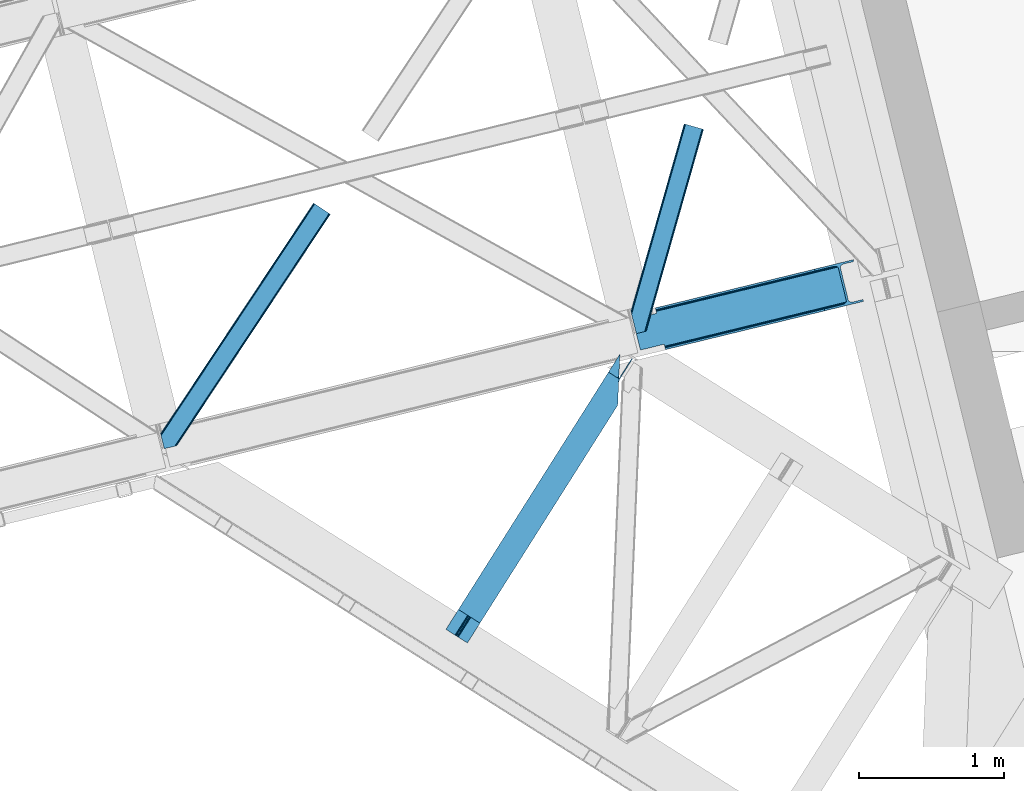
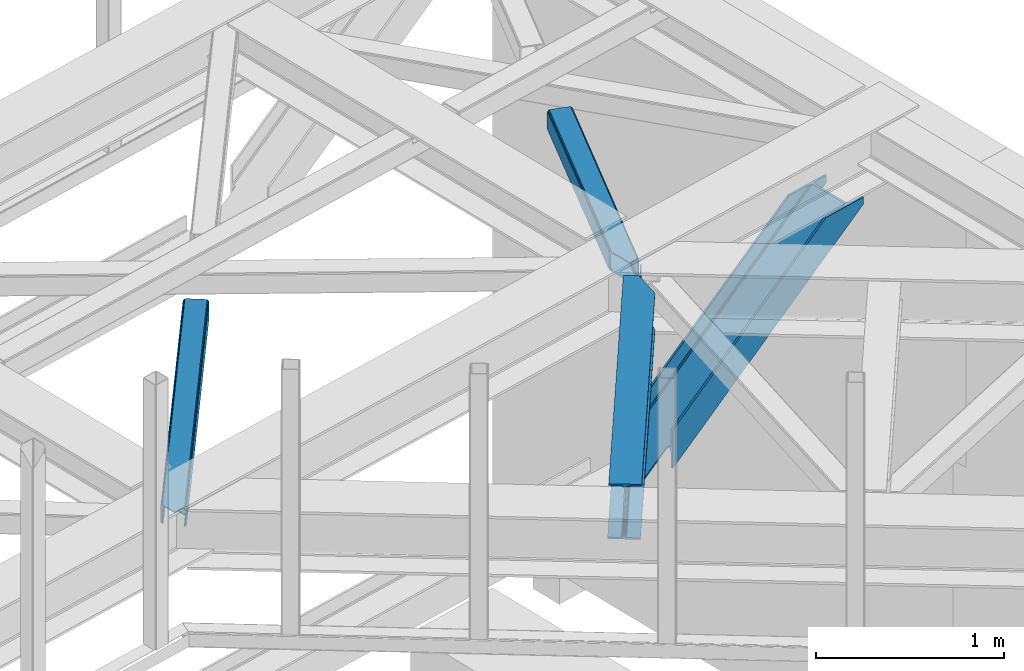
# One storey, part 58 of 67: 3 members, 1 beam.
"""IFC4 building model written with IfcOpenShell, lengths in millimetres."""

from ifc_helpers import new_model, entity, si_unit, converted_unit, derived_unit, direction, frame, origin, place, context, subcontext, project, spatial, triangles, polygons, type_object, element, save


model = new_model("IFC4")

# Units and contexts
model_context = context("Model", 3, precision=0.01, world=origin(), true_north=direction((6.12303176911189e-17, 1.0)))
plan_context = context("Plan", 3, precision=0.01, world=origin(), true_north=direction((6.12303176911189e-17, 1.0)))
body_context = subcontext(model_context, "Body", "Model", "MODEL_VIEW")
ifc_project = project(units=[si_unit("LENGTHUNIT", "METRE", prefix="MILLI"), si_unit("AREAUNIT", "SQUARE_METRE"), si_unit("VOLUMEUNIT", "CUBIC_METRE"), converted_unit("PLANEANGLEUNIT", "DEGREE", entity("IfcRatioMeasure", 0.0174532925199433), si_unit("PLANEANGLEUNIT", "RADIAN"), dimensions=[0, 0, 0, 0, 0, 0, 0]), si_unit("MASSUNIT", "GRAM", prefix="KILO"), derived_unit("MASSDENSITYUNIT", [(si_unit("MASSUNIT", "GRAM", prefix="KILO"), 1), (si_unit("LENGTHUNIT", "METRE"), -3)]), derived_unit("MOMENTOFINERTIAUNIT", [(si_unit("LENGTHUNIT", "METRE"), 4)]), si_unit("TIMEUNIT", "SECOND"), si_unit("FREQUENCYUNIT", "HERTZ"), si_unit("THERMODYNAMICTEMPERATUREUNIT", "DEGREE_CELSIUS"), derived_unit("THERMALTRANSMITTANCEUNIT", [(si_unit("MASSUNIT", "GRAM", prefix="KILO"), 1), (si_unit("THERMODYNAMICTEMPERATUREUNIT", "KELVIN"), -1), (si_unit("TIMEUNIT", "SECOND"), -3)]), derived_unit("VOLUMETRICFLOWRATEUNIT", [(si_unit("LENGTHUNIT", "METRE"), 3), (si_unit("TIMEUNIT", "SECOND"), -1)]), derived_unit("MASSFLOWRATEUNIT", [(si_unit("MASSUNIT", "GRAM", prefix="KILO"), 1), (si_unit("TIMEUNIT", "SECOND"), -1)]), derived_unit("ROTATIONALFREQUENCYUNIT", [(si_unit("TIMEUNIT", "SECOND"), -1)]), si_unit("ELECTRICCURRENTUNIT", "AMPERE"), si_unit("ELECTRICVOLTAGEUNIT", "VOLT"), si_unit("POWERUNIT", "WATT"), si_unit("FORCEUNIT", "NEWTON", prefix="KILO"), si_unit("ILLUMINANCEUNIT", "LUX"), si_unit("LUMINOUSFLUXUNIT", "LUMEN"), si_unit("LUMINOUSINTENSITYUNIT", "CANDELA"), derived_unit("USERDEFINED", [(si_unit("MASSUNIT", "GRAM", prefix="KILO"), -1), (si_unit("LENGTHUNIT", "METRE"), -2), (si_unit("TIMEUNIT", "SECOND"), 3), (si_unit("LUMINOUSFLUXUNIT", "LUMEN"), 1)]), derived_unit("LINEARVELOCITYUNIT", [(si_unit("LENGTHUNIT", "METRE"), 1), (si_unit("TIMEUNIT", "SECOND"), -1)]), si_unit("PRESSUREUNIT", "PASCAL"), derived_unit("USERDEFINED", [(si_unit("LENGTHUNIT", "METRE"), -2), (si_unit("MASSUNIT", "GRAM", prefix="KILO"), 1), (si_unit("TIMEUNIT", "SECOND"), -2)]), derived_unit("LINEARFORCEUNIT", [(si_unit("MASSUNIT", "GRAM", prefix="KILO"), 1), (si_unit("LENGTHUNIT", "METRE"), 1), (si_unit("TIMEUNIT", "SECOND"), -2), (si_unit("LENGTHUNIT", "METRE"), -1)]), derived_unit("PLANARFORCEUNIT", [(si_unit("MASSUNIT", "GRAM", prefix="KILO"), 1), (si_unit("LENGTHUNIT", "METRE"), 1), (si_unit("TIMEUNIT", "SECOND"), -2), (si_unit("LENGTHUNIT", "METRE"), -2)])], contexts=[model_context, plan_context])

# Site, building, storey
site_placement = place(None, origin())
site = spatial("IfcSite", under=ifc_project, at=site_placement, CompositionType="ELEMENT")
building_placement = place(site_placement, origin())
building = spatial("IfcBuilding", under=site, at=building_placement, CompositionType="ELEMENT")
storey_placement = place(building_placement, frame((0.0, 0.0, 19800.0)))
storey = spatial("IfcBuildingStorey", under=building, at=storey_placement, CompositionType="ELEMENT", Elevation=19800.0)

# Member
member_type_1 = type_object("IfcMemberType", PredefinedType="BRACE")
member_1_placement = place(storey_placement, frame((-2187.21835717023, 16968.3557591435, 2617.59591122081)))
element("IfcMember", 1, at=member_1_placement, inside=storey, type_object=member_type_1, ObjectType="Steel Vertical Brace", PredefinedType="BRACE", context=body_context, shape_type="Tessellation", body=[
    polygons([(1585.2294851225, 334.661161692477, 1042.42673521894), (1582.15074591362, 347.291338448318, 1042.42673521894), (1582.15074591362, 347.291338448318, 1088.40408877919), (1585.2294851225, 334.661161692477, 1088.40408877919), (225.056603724453, 3.10463150600978, 5.98026597646167), (221.977864515578, 15.7348082618462, 5.98026597646167), (221.977864515577, 15.7348082618462, 102.718017134371), (1515.53571242156, 331.05321926145, 1088.40408877919), (225.056603724452, 3.10463150600761, 254.823355771723), (1319.00013205867, 269.76494023208, 1088.40408877919), (217.714994841749, 33.2227453083898, 135.689726532239), (216.294038283798, 39.0520576572405, 135.689726532152), (216.294038283802, 39.0520576572405, 125.113895215846), (217.714994841748, 33.2227453083941, 125.113895215941), (219.346324440217, 26.5304015345462, 123.409110506461), (220.729298895395, 20.8569064339283, 118.554294396374), (221.653372883131, 17.0659982053532, 111.288548629352), (221.977864515572, 15.7348082618462, 254.823355771723), (221.977864515573, 15.7348082618462, 158.085604613814), (221.653372883133, 17.0659982053446, 149.515073118633), (220.729298895395, 20.856906433924, 142.249327351612), (219.346324440223, 26.5304015345462, 137.394511241533), (1451.82949340716, 592.400722901503, 1088.40408877919), (1518.44452689923, 608.638842088371, 1088.40408877919), (1515.36578769035, 621.269018844214, 1088.40408877919), (1249.13643462652, 556.372797383815, 1088.40408877919), (1252.21517383539, 543.742620627976, 1088.40408877919), (1379.16824824607, 574.688775652657, 1088.40408877919), (1390.74021368898, 576.099276446501, 1088.40408877919), (1401.19943555815, 574.632661393906, 1088.40408877918), (1408.95359213711, 570.512209341736, 1088.40408877919), (1412.8221833783, 564.365221762941, 1088.40408877919), (1468.00266304505, 337.993592215981, 1088.40408877919), (1467.39673100087, 330.755892246851, 1088.40408877919), (1462.40852333225, 323.529354097781, 1088.40408877919), (1453.79744943855, 317.414152693241, 1088.40408877919), (1442.87446726047, 313.341272012599, 1088.40408877919), (1315.92139284979, 282.395116987918, 1088.40408877918), (1503.96374697866, 329.64271846761, 1088.40408877919), (1493.50452510946, 331.109333520199, 1088.40408877918), (1485.7503685305, 335.229785572367, 1088.40408877918), (1481.8817772893, 341.376773151153, 1088.40408877919), (1426.70129762255, 567.748402698115, 1088.40408877919), (1427.30722966674, 574.986102667243, 1088.40408877919), (1432.29543733536, 582.212640816317, 1088.40408877919), (1440.90651122909, 588.327842220875, 1088.40408877919), (3.24860138789518e-12, 212.769900732995, 1.8192167772213e-10), (163.220745767809, 252.556684355379, 124.373576309325), (163.955471732924, 253.765062506503, 125.113895215868), (162.534515175014, 259.594374855358, 125.113895215928), (215.085660132705, 39.7867836223989, 124.373576309312), (51.8649143648549, 4.33146851719357e-12, 6.49720277579036e-11), (162.534515175012, 259.594374855358, 135.689726532226), (163.95547173292, 253.765062506501, 135.68972653217), (163.220745767806, 252.556684355379, 134.949407625623), (2.8966695708732e-11, 212.769900732999, 10.5758313165188), (51.8649143648817, 1.08286712929839e-11, 10.5758313164365), (215.085660132696, 39.7867836223968, 134.949407625615), (160.903185576499, 266.286718629312, 137.394511241728), (159.520211121322, 271.960213729928, 142.249327351807), (158.596137133586, 275.751121958501, 149.515073118828), (158.271645501173, 277.082311901899, 158.085604613814), (158.271645501172, 277.082311901899, 254.823355771723), (155.192906292298, 289.712488657742, 254.823355771723), (155.192906292296, 289.712488657742, 5.98026597646167), (158.271645501172, 277.082311901899, 5.98026597646167), (158.271645501173, 277.082311901904, 102.718017134371), (158.59613713359, 275.751121958499, 111.28854862956), (159.520211121322, 271.960213729926, 118.554294396582), (160.903185576492, 266.28671862931, 123.409110506656), (1518.44452689923, 608.638842088371, 1042.42673521895), (1515.36578769035, 621.269018844214, 1042.42673521894)], [[[1, 2, 3, 4]], [[5, 6, 2, 1]], [[6, 7, 8, 3, 2]], [[9, 5, 1, 4, 10]], [[11, 12, 13, 14, 15, 16, 17, 7, 6, 5, 9, 18, 19, 20, 21, 22]], [[23, 24, 25, 26, 27, 28, 29, 30, 31, 32, 33, 34, 35, 36, 37, 38, 10, 4, 3, 8, 39, 40, 41, 42, 43, 44, 45, 46]], [[42, 41, 15, 14]], [[41, 40, 16, 15]], [[40, 39, 17, 16]], [[39, 8, 7, 17]], [[18, 9, 10, 38]], [[19, 18, 38, 37]], [[37, 36, 20, 19]], [[36, 35, 21, 20]], [[35, 34, 22, 21]], [[34, 33, 11, 22]], [[47, 48, 49, 50, 43, 42, 14, 13, 51, 52]], [[53, 54, 55, 56, 57, 58, 12, 11, 33, 32]], [[58, 57, 52, 51]], [[57, 56, 47, 52]], [[56, 55, 48, 47]], [[54, 53, 59, 60, 61, 62, 63, 64, 65, 66, 67, 68, 69, 70, 50, 49]], [[23, 46, 68, 67]], [[46, 45, 69, 68]], [[45, 44, 70, 69]], [[44, 43, 50, 70]], [[67, 66, 71, 24, 23]], [[72, 25, 24, 71]], [[66, 65, 72, 71]], [[65, 64, 26, 25, 72]], [[32, 31, 59, 53]], [[31, 30, 60, 59]], [[30, 29, 61, 60]], [[29, 28, 62, 61]], [[63, 62, 28, 27]], [[64, 63, 27, 26]]], closed=False),
])

# Beam
beam_type = type_object("IfcBeamType", PredefinedType="BEAM")
beam_placement = place(storey_placement, frame((-3471.97848129272, 14954.9604217529, 3863.99976196289)))
element("IfcBeam", 2, at=beam_placement, inside=storey, type_object=beam_type, ObjectType="Steel Beam", PredefinedType="BEAM", context=body_context, shape_type="Tessellation", body=[
    triangles([(1188.72613334656, 1816.41354675293, 230.999853515623), (1188.08329467773, 1793.75679016113, 228.313970947263), (1188.92815589905, 1796.73218994141, 227.025677490234), (1187.41618423462, 1786.02702941895, 230.999853515623), (1190.21528663635, 1815.46941833496, 227.193109130858), (1191.30315628052, 1805.13516540527, 223.384039306638), (1194.96863021851, 1812.46611328125, 221.005114746094), (1191.70894546509, 1814.52645263672, 223.384039306638), (1191.71897392273, 1805.96185913086, 223.116613769529), (163.219397735596, 181.395904541016, 217.00070800781), (1194.53856925964, 1812.73818969727, 217.00070800781), (164.249276733398, 180.744781494141, 223.123590087889), (167.180783843994, 178.891406250001, 228.313970947263), (1187.27709388733, 1782.76792602539, 231.783526611329), (1186.75067253113, 1770.47332763672, 232.99973144531), (171.567144012451, 176.117156982422, 231.783526611329), (176.744734954834, 172.846426391601, 232.99973144531), (1180.87254295349, 1633.92584838867, 232.99973144531), (234.219715118408, 136.50910949707, 232.99973144531), (1188.72613334656, 1816.41354675293, 244.001385498046), (1180.87254295349, 1633.92584838867, 244.001385498046), (234.219715118408, 136.50910949707, 244.001385498046), (1117.61957244873, 1861.36429138184, 244.001385498046), (86.3005462646483, 230.022006225587, 244.001385498046), (1117.61957244873, 1861.36429138184, 232.99973144531), (86.3005462646483, 230.022006225587, 232.99973144531), (1175.09905815125, 1825.02813720703, 232.99973144531), (143.779886627197, 193.685852050781, 232.99973144531), (1187.59422569275, 1817.12978210449, 223.123590087889), (1188.62410469055, 1816.47865905762, 217.00070800781), (157.300572967529, 185.135211181641, 217.00070800781), (156.270693969726, 185.786334228516, 223.123590087889), (1184.66271858215, 1818.98315734863, 228.313970947263), (153.339186859131, 187.639709472656, 228.313970947263), (1180.27214355469, 1821.75624389649, 231.783526611329), (148.953117370605, 190.413958740235, 231.783526611329), (1188.62410469055, 1816.47865905762, 204.001501464842), (1194.53856925964, 1812.73818969727, 204.001501464842), (163.219397735596, 181.395904541016, 204.001501464842), (157.300572967529, 185.135211181641, 204.001501464842), (1284.44601745605, 1954.95276489258, 202.999237060547), (1278.52704734802, 1958.6920715332, 202.999237060547), (1195.07443771362, 1813.58348693848, 202.999237060547), (1189.15546760559, 1817.32395629883, 202.999237060547), (1284.44601745605, 1954.95276489258, 119.99965209961), (1278.52704734802, 1958.6920715332, 119.99965209961), (162.88715057373, 180.872680664063, 203.057373046875), (156.76921005249, 184.291076660156, 202.999237060547), (76.9188514709472, 44.8867950439453, 202.999237060547), (71.0000267028809, 48.626101684571, 202.999237060547), (1200.5501209259, 1835.34494934082, 119.99965209961), (1199.94579734802, 1821.28883056641, 119.99965209961), (1196.02728652954, 1828.19306030274, 119.162493896485), (1195.42281761169, 1814.13694152832, 119.162493896485), (1192.19612503052, 1822.13180236816, 116.778918457032), (1191.59180145264, 1808.07568359375, 116.778918457032), (1189.63639755249, 1818.08088684082, 113.209368896485), (1189.03192863464, 1804.02476806641, 113.209368896485), (1188.73383636475, 1816.65771789551, 109.000323486329), (1188.12951278687, 1802.6015991211, 109.000323486329), (1188.95184631348, 1817.00072021484, 203.075976562501), (1188.73383636475, 1816.65771789551, 27.0006774902322), (71.0000267028809, 48.626101684571, 27.0006774902322), (1189.59076080322, 1836.49139099121, 12.2178588867173), (1190.11718215942, 1848.78598937988, 10.9993286132813), (57.4793403625486, 57.1779052734382, 10.9993286132813), (62.6525711059571, 53.9048492431648, 12.2178588867173), (1189.13977088928, 1826.06760864258, 15.6874145507791), (67.0432914733888, 51.1317626953132, 15.6874145507791), (1188.84124259949, 1819.10291748047, 20.877795410157), (69.9747985839845, 49.2783874511715, 20.877795410157), (1195.99080619812, 1985.3323059082, 10.9993286132813), (0.0, 93.5140594482418, 10.9993286132813), (1195.99080619812, 1985.3323059082, 0.0), (0.0, 93.5140594482418, 0.0), (1180.87254295349, 1633.92584838867, 0.0), (147.91916885376, 0.0, 0.0), (85.2665977478027, 39.6080474853516, 12.2178588867173), (80.8802375793457, 42.3822967529304, 15.6874145507791), (76.9188514709472, 44.8867950439453, 27.0006774902322), (77.94873046875, 44.2356719970703, 20.877795410157), (90.4441886901855, 36.3373168945309, 10.9993286132813), (147.91916885376, 0.0, 10.9993286132813), (1187.27709388733, 1782.76792602539, 12.2178588867173), (1186.75067253113, 1770.47332763672, 10.9993286132813), (1188.02661209106, 1800.15639953613, 20.877795410157), (1187.7279384613, 1793.19170837402, 15.6874145507791), (1188.12951278687, 1802.6015991211, 27.0006774902322), (1180.87254295349, 1633.92584838867, 10.9993286132813)], [[1, 2, 3], [1, 4, 2], [5, 3, 6], [7, 8, 9], [6, 9, 8], [6, 8, 5], [3, 5, 1], [10, 11, 9], [11, 7, 9], [12, 9, 6], [6, 13, 12], [6, 3, 13], [2, 13, 3], [13, 4, 14], [13, 2, 4], [14, 15, 16], [17, 16, 15], [14, 16, 13], [9, 12, 10], [15, 18, 17], [19, 17, 18], [20, 14, 4], [14, 20, 15], [4, 1, 20], [21, 15, 20], [21, 18, 15], [18, 21, 22], [22, 19, 18], [21, 23, 24], [23, 21, 20], [24, 22, 21], [23, 25, 24], [26, 24, 25], [25, 27, 28], [28, 26, 25], [29, 30, 31], [31, 32, 29], [33, 29, 32], [32, 34, 33], [35, 33, 36], [34, 36, 33], [27, 35, 36], [36, 28, 27], [1, 35, 20], [8, 7, 11], [30, 11, 37], [37, 11, 38], [8, 29, 5], [11, 30, 8], [5, 33, 1], [27, 20, 35], [33, 5, 29], [30, 29, 8], [33, 35, 1], [27, 23, 20], [23, 27, 25], [13, 16, 36], [17, 22, 24], [19, 22, 17], [16, 17, 28], [10, 12, 32], [12, 13, 32], [39, 10, 40], [34, 13, 36], [24, 28, 17], [28, 36, 16], [24, 26, 28], [32, 31, 10], [31, 40, 10], [34, 32, 13], [41, 42, 43], [44, 43, 42], [41, 45, 42], [46, 42, 45], [47, 48, 49], [50, 49, 48], [46, 45, 51], [52, 51, 45], [51, 52, 53], [54, 53, 52], [53, 54, 55], [56, 55, 54], [57, 55, 56], [56, 58, 57], [59, 57, 58], [58, 60, 59], [57, 37, 61], [57, 61, 55], [53, 55, 61], [42, 46, 51], [51, 61, 42], [61, 51, 53], [62, 48, 59], [59, 48, 31], [63, 48, 62], [63, 50, 48], [31, 37, 59], [59, 37, 57], [31, 30, 37], [64, 65, 66], [66, 67, 64], [68, 64, 67], [67, 69, 68], [70, 68, 69], [69, 71, 70], [62, 70, 71], [71, 63, 62], [65, 72, 73], [73, 66, 65], [72, 74, 75], [75, 73, 72], [74, 76, 75], [77, 75, 76], [78, 79, 67], [80, 71, 81], [79, 81, 69], [80, 49, 63], [82, 75, 77], [77, 83, 82], [82, 78, 66], [67, 79, 69], [71, 80, 63], [50, 63, 49], [71, 69, 81], [75, 82, 66], [67, 66, 78], [73, 75, 66], [68, 64, 84], [65, 74, 76], [72, 74, 65], [64, 65, 85], [62, 70, 86], [70, 68, 87], [59, 62, 88], [87, 68, 84], [76, 85, 65], [85, 84, 64], [76, 89, 85], [86, 88, 62], [88, 60, 59], [87, 86, 70], [86, 88, 80], [80, 81, 86], [87, 86, 81], [81, 79, 87], [84, 87, 79], [79, 78, 84], [85, 84, 78], [78, 82, 85], [89, 85, 82], [82, 83, 89], [76, 89, 77], [83, 77, 89]]),
])

# Members
member_type_2 = type_object("IfcMemberType", PredefinedType="BRACE")
member_2_placement = place(storey_placement, frame((-5433.35323791504, 16290.2998443604, 3823.02086791992)))
element("IfcMember", 3, at=member_2_placement, inside=storey, type_object=member_type_2, ObjectType="Steel Horizontal Brace", PredefinedType="BRACE", context=body_context, shape_type="Tessellation", body=[
    triangles([(1167.55605926514, 1611.29350891113, 17.4989318847656), (1167.55605926514, 1611.29350891113, 122.499499511716), (112.764628601074, 21.275445556641, 17.4989318847656), (112.764628601074, 21.275445556641, 122.499499511716), (1166.44769668579, 1612.03067321777, 129.196765136716), (110.858349609375, 20.810357666016, 129.196765136716), (1163.28451766968, 1614.12705688477, 134.873162841795), (105.426704406738, 19.486019897462, 134.873162841795), (1158.55573654175, 1617.26640014649, 138.668280029295), (97.3022003173828, 17.5059082031257, 138.668280029295), (1152.97613525391, 1620.96849975586, 139.998431396481), (87.713832092285, 15.1688415527351, 139.998431396481), (5.64326019287091, 81.3950317382823, 139.998431396481), (1065.47537155151, 1679.01263122559, 139.998431396481), (25.4839096069336, 0.0, 139.998431396481), (1059.89577026367, 1682.71473083496, 138.668280029295), (3.48350830078107, 90.2537933349613, 138.668280029295), (1055.16698913574, 1685.85407409668, 134.873162841795), (1.65280609130878, 97.7649627685551, 134.873162841795), (1052.00381011963, 1687.95045776367, 129.196765136716), (0.42962493896448, 102.7832611084, 129.196765136716), (1050.89573822022, 1688.68762207031, 122.499499511716), (0.0, 104.544781494142, 122.499499511716), (1050.89573822022, 1688.68762207031, 17.4989318847656), (0.0, 104.544781494142, 17.4989318847656), (1166.44769668579, 1612.03067321777, 10.8016662597656), (1163.28451766968, 1614.12705688477, 5.12526855468604), (159.822802734375, 95.9557708740231, 9.25757446288844), (160.257078552246, 97.3742889404293, 8.49948120117188), (159.407711791992, 100.858959960939, 5.12526855468604), (110.469419860839, 20.7150146484382, 10.8691040039048), (109.995030212403, 20.5999053955074, 9.49942016601563), (1152.97613525391, 1620.96849975586, 0.0), (1158.55573654175, 1617.26640014649, 1.33247680663771), (155.417839050293, 117.227728271484, 0.0), (157.577009582519, 108.368966674805, 1.33247680663771), (1065.47537155151, 1679.01263122559, 0.0), (121.558859252929, 256.129714965822, 0.0), (155.314356994629, 113.429122924807, 9.49942016601563), (90.5967956542972, 15.8711242675781, 9.49942016601563), (155.425978088379, 114.267443847655, 9.2947814941399), (155.539343261718, 115.1185546875, 9.08781738280959), (160.118714904786, 96.9219909667972, 8.74132690429542), (155.650964355469, 115.956875610353, 8.8831787109375), (155.446325683593, 117.1102935791, 8.49948120117188), (1152.72004623413, 1621.13593139648, 8.33204956054396), (1147.14073562622, 1624.83803100586, 6.99957275390625), (153.160418701172, 126.488790893554, 6.99957275390625), (1157.45347824097, 1617.99775085449, 12.1248413085923), (95.4092926025387, 17.0443084716808, 12.1248413085923), (1161.72501983643, 1615.16420288086, 24.4985046386719), (1160.61200637817, 1615.90020446777, 17.8035644531228), (102.742565917969, 18.8325714111324, 24.4985046386719), (100.835705566406, 18.3674835205074, 17.8035644531228), (1161.72501983643, 1615.16420288086, 115.49992675781), (102.742565917969, 18.8325714111324, 115.49992675781), (100.835705566406, 18.3674835205074, 122.19719238281), (87.2801376342777, 15.0630340576172, 131.666381835938), (77.6917694091799, 12.7259674072266, 132.998858642575), (25.4839096069336, 0.0, 132.998858642575), (95.4092926025387, 17.0443084716808, 127.873590087889), (1147.14073562622, 1624.83803100586, 132.998858642575), (1152.72004623413, 1621.13593139648, 131.666381835938), (1157.45347824097, 1617.99775085449, 127.873590087889), (1160.61200637817, 1615.90020446777, 122.19719238281), (7.90068054199219, 72.1351318359375, 132.998858642575), (1071.3107711792, 1675.14309997558, 132.998858642575), (1056.72648696899, 1684.81692810058, 115.49992675781), (1057.83950042725, 1684.0820892334, 122.19719238281), (2.25742034912128, 95.2848815917987, 115.49992675781), (2.68704528808576, 93.5233612060547, 122.19719238281), (1060.99802856445, 1681.98338012695, 127.873590087889), (3.91022644043005, 88.505062866212, 127.873590087889), (1065.73146057129, 1678.84636230469, 131.666381835938), (5.74092864990234, 80.9938934326183, 131.666381835938), (1060.99802856445, 1681.98338012695, 12.1248413085923), (1059.89577026367, 1682.71473083496, 1.33247680663771), (1055.16698913574, 1685.85407409668, 5.12526855468604), (1071.3107711792, 1675.14309997558, 6.99957275390625), (1065.73146057129, 1678.84636230469, 8.33204956054396), (1056.72648696899, 1684.81692810058, 24.4985046386719), (1052.00381011963, 1687.95045776367, 10.8016662597656), (1057.83950042725, 1684.0820892334, 17.8035644531228), (2.25742034912128, 95.2848815917987, 24.4985046386719), (123.816279602051, 246.869815063475, 6.99957275390625), (2.88121948242224, 92.7245727539066, 16.4989929199219), (2.77483062744159, 93.1629180908203, 17.868676757811), (0.0093017578128638, 104.50757446289, 16.4989929199219), (119.399688720703, 264.988476562501, 1.33247680663771), (121.662922668457, 255.702996826172, 8.41343994140334), (117.568986511231, 272.499645996095, 5.12526855468604), (116.719619750977, 275.983154296877, 8.49948120117188), (4.73924560546857, 108.865447998049, 10.8714294433594), (115.787118530274, 275.584341430664, 9.49942016601563), (5.89266357421911, 109.927011108399, 9.49942016601563), (7.20479278564471, 93.4687133789066, 12.1248413085923), (120.157200622559, 257.658691406252, 9.49942016601563), (121.184463500977, 256.801766967774, 8.80643920898365), (10.2621643066404, 92.0013610839851, 9.49942016601563)], [[1, 2, 3], [4, 3, 2], [2, 5, 4], [6, 4, 5], [5, 7, 6], [8, 6, 7], [7, 9, 8], [10, 8, 9], [9, 11, 10], [12, 10, 11], [11, 13, 12], [11, 14, 13], [13, 15, 12], [14, 16, 17], [17, 13, 14], [16, 18, 19], [19, 17, 16], [18, 20, 21], [21, 19, 18], [20, 22, 23], [23, 21, 20], [22, 24, 23], [25, 23, 24], [26, 1, 3], [27, 28, 29], [29, 30, 27], [26, 31, 28], [28, 27, 26], [31, 32, 28], [33, 34, 35], [36, 35, 34], [34, 27, 36], [30, 36, 27], [3, 31, 26], [37, 33, 38], [35, 38, 33], [39, 28, 32], [32, 40, 39], [39, 41, 28], [41, 42, 43], [42, 44, 43], [44, 45, 29], [46, 47, 48], [49, 46, 45], [45, 44, 49], [49, 42, 41], [42, 49, 44], [41, 39, 49], [49, 39, 50], [40, 50, 39], [48, 45, 46], [51, 52, 53], [54, 53, 52], [52, 49, 54], [50, 54, 49], [55, 51, 53], [53, 56, 55], [57, 4, 6], [58, 10, 12], [15, 59, 12], [59, 15, 60], [59, 58, 12], [61, 10, 58], [61, 57, 8], [8, 10, 61], [6, 8, 57], [53, 3, 4], [50, 32, 54], [57, 56, 4], [50, 40, 32], [53, 54, 3], [56, 53, 4], [31, 3, 54], [54, 32, 31], [62, 63, 58], [58, 59, 62], [63, 64, 61], [61, 58, 63], [64, 65, 57], [57, 61, 64], [65, 55, 56], [56, 57, 65], [62, 66, 67], [66, 62, 59], [60, 66, 59], [68, 69, 70], [71, 70, 69], [69, 72, 71], [73, 71, 72], [72, 74, 73], [75, 73, 74], [74, 67, 75], [66, 75, 67], [26, 49, 52], [51, 2, 1], [26, 52, 1], [26, 27, 49], [52, 51, 1], [49, 27, 34], [47, 33, 37], [33, 46, 34], [46, 33, 47], [46, 49, 34], [5, 64, 7], [55, 2, 51], [2, 65, 5], [65, 2, 55], [5, 65, 64], [11, 62, 14], [9, 7, 64], [64, 63, 9], [63, 62, 11], [11, 9, 63], [76, 77, 78], [37, 79, 47], [37, 80, 79], [80, 37, 77], [76, 80, 77], [81, 24, 22], [82, 83, 76], [78, 82, 76], [83, 82, 24], [81, 83, 24], [16, 72, 18], [14, 62, 67], [67, 74, 14], [74, 72, 16], [16, 14, 74], [20, 18, 72], [22, 68, 81], [69, 22, 20], [22, 69, 68], [69, 20, 72], [81, 68, 84], [70, 84, 68], [47, 79, 85], [85, 48, 47], [75, 66, 13], [66, 15, 13], [66, 60, 15], [17, 75, 13], [73, 17, 19], [73, 75, 17], [86, 87, 88], [23, 70, 71], [71, 19, 21], [19, 71, 73], [21, 23, 71], [23, 84, 70], [25, 88, 87], [25, 84, 23], [84, 25, 87], [85, 38, 48], [89, 90, 91], [90, 89, 38], [91, 90, 92], [38, 85, 90], [48, 38, 35], [36, 45, 35], [45, 36, 30], [35, 45, 48], [30, 29, 45], [24, 82, 93], [93, 25, 24], [94, 93, 82], [94, 95, 93], [78, 91, 92], [92, 82, 78], [92, 94, 82], [78, 77, 91], [89, 91, 77], [77, 37, 89], [38, 89, 37], [93, 88, 25], [83, 81, 84], [83, 86, 96], [83, 87, 86], [80, 97, 98], [76, 96, 97], [97, 80, 76], [96, 99, 97], [79, 80, 90], [90, 85, 79], [96, 76, 83], [84, 87, 83], [95, 96, 93], [95, 99, 96], [96, 88, 93], [86, 88, 96], [94, 97, 95], [99, 95, 97]]),
])
member_type_3 = type_object("IfcMemberType", PredefinedType="BRACE")
member_3_placement = place(storey_placement, frame((-2200.60041618347, 17081.2992370605, 3823.02086791992)))
element("IfcMember", 4, at=member_3_placement, inside=storey, type_object=member_type_3, ObjectType="Steel Horizontal Brace", PredefinedType="BRACE", context=body_context, shape_type="Tessellation", body=[
    triangles([(382.458631896973, 1437.45993347168, 139.998431396481), (376.014548492432, 1439.28889160157, 138.668280029295), (5.18718338012695, 133.445343017578, 138.668280029295), (8.40283012390137, 120.253125000003, 139.998431396481), (370.552672576904, 1440.83879699707, 134.873162841795), (2.46118698120108, 144.628381347658, 134.873162841795), (366.905947494507, 1441.87594299317, 129.196765136716), (0.639641189575286, 152.101181030273, 129.196765136716), (365.625211715698, 1442.23987426758, 122.499499511716), (0.0, 154.725439453126, 122.499499511716), (365.625211715698, 1442.23987426758, 17.4989318847656), (0.0, 154.725439453126, 17.4989318847656), (86.8012424468993, 11.9643859863281, 139.998431396481), (483.46365852356, 1408.77563781738, 139.998431396481), (37.7160118103025, 0.0, 139.998431396481), (500.297078704834, 1403.99453430176, 122.499499511716), (499.016342926025, 1404.35846557617, 129.196765136716), (106.348595809936, 16.7292114257834, 122.499499511716), (104.86191329956, 16.3664428710945, 129.196765136716), (495.369617843628, 1405.39561157227, 134.873162841795), (100.623509216308, 15.3339477539084, 134.873162841795), (489.9077419281, 1406.9466796875, 138.668280029295), (94.2839252471922, 13.7886932373076, 138.668280029295), (500.297078704834, 1403.99453430176, 17.4989318847656), (106.348595809936, 16.7292114257834, 17.4989318847656), (370.552672576904, 1440.83879699707, 5.12526855468604), (376.014548492432, 1439.28889160157, 1.33247680663771), (64.4095859527588, 341.997729492188, 1.33247680663771), (366.905947494507, 1441.87594299317, 10.8016662597656), (57.6633407592772, 340.35364379883, 5.49966430664063), (1.58013610839816, 155.411444091798, 10.8016662597656), (0.350269317626953, 153.288317871094, 12.4992370605469), (6.16328659057626, 158.997271728516, 5.49966430664063), (382.458631896973, 1437.45993347168, 0.0), (71.8924140930176, 343.822036743164, 0.0), (101.030170440674, 15.4327789306662, 5.49966430664063), (149.676183700562, 186.73860168457, 5.49966430664063), (44.5164688110349, 1.65687561035156, 5.49966430664063), (109.170516586304, 352.90869140625, 5.49966430664063), (149.709902572632, 188.722201538087, 4.99969482421875), (489.9077419281, 1406.9466796875, 1.33247680663771), (495.369617843628, 1405.39561157227, 5.12526855468604), (149.739115905762, 190.703475952148, 4.49972534179688), (149.724436569214, 189.72214050293, 4.74622192382594), (147.329379272461, 200.588919067384, 1.33247680663771), (499.016342926025, 1404.35846557617, 10.8016662597656), (104.86191329956, 16.3664428710945, 10.8016662597656), (149.690717697144, 187.719937133792, 5.25084228515334), (483.46365852356, 1408.77563781738, 0.0), (144.113877868652, 213.779974365236, 0.0), (110.142114257812, 353.145886230472, 0.0), (109.541133499145, 352.999383544924, 5.42292480468677), (110.142114257812, 353.145886230472, 4.49972534179688), (43.0614704132081, 1.30224609375, 6.99957275390625), (14.8120319366453, 117.192846679689, 6.99957275390625), (10.8560234069823, 127.785223388673, 8.33204956054396), (5.64776573181143, 131.555923461914, 12.4992370605469), (377.289616012573, 1438.92844848633, 12.1248413085923), (373.638385391235, 1439.96326904297, 17.8035644531228), (4.00077323913547, 138.312487792969, 17.8035644531228), (389.191069793701, 1435.54725952149, 6.99957275390625), (382.751637268066, 1437.37738037109, 8.33204956054396), (372.357649612427, 1440.32720031738, 24.4985046386719), (3.36113204956064, 140.936746215823, 24.4985046386719), (78.9841323852538, 10.0586883544929, 6.99957275390625), (476.731220626831, 1410.68831176758, 6.99957275390625), (372.357649612427, 1440.32720031738, 115.49992675781), (3.36113204956064, 140.936746215823, 115.49992675781), (5.82231903076172, 130.839688110354, 127.873590087889), (4.00077323913547, 138.312487792969, 122.19719238281), (8.54831542968759, 119.656649780274, 131.666381835938), (11.763962173462, 106.464431762695, 132.998858642575), (37.7160118103025, 0.0, 132.998858642575), (373.638385391235, 1439.96326904297, 122.19719238281), (377.289616012573, 1438.92844848633, 127.873590087889), (382.751637268066, 1437.37738037109, 131.666381835938), (389.191069793701, 1435.54725952149, 132.998858642575), (78.9841323852538, 10.0586883544929, 132.998858642575), (476.731220626831, 1410.68831176758, 132.998858642575), (488.632529067993, 1407.30712280274, 12.1248413085923), (492.283905029297, 1406.27113952637, 17.8035644531228), (493.564640808105, 1405.90720825196, 24.4985046386719), (483.175158691406, 1408.8593536377, 8.33204956054396), (488.632529067993, 1407.30712280274, 127.873590087889), (493.564640808105, 1405.90720825196, 115.49992675781), (492.283905029297, 1406.27113952637, 122.19719238281), (483.175158691406, 1408.8593536377, 131.666381835938), (86.4623096466062, 11.8818328857451, 131.666381835938), (92.8063991546628, 13.4282501220732, 127.873590087889), (97.0402976989744, 14.4607452392593, 122.19719238281), (98.5314857482908, 14.8235137939482, 115.49992675781), (86.4623096466062, 11.8818328857451, 8.33204956054396), (97.0402976989744, 14.4607452392593, 17.8035644531228), (92.8063991546628, 13.4282501220732, 12.1248413085923), (98.5314857482908, 14.8235137939482, 24.4985046386719)], [[1, 2, 3], [3, 4, 1], [2, 5, 6], [6, 3, 2], [5, 7, 8], [8, 6, 5], [7, 9, 10], [10, 8, 7], [9, 11, 12], [12, 10, 9], [4, 13, 14], [13, 4, 15], [14, 1, 4], [16, 17, 18], [19, 18, 17], [17, 20, 19], [21, 19, 20], [20, 22, 21], [23, 21, 22], [22, 14, 23], [13, 23, 14], [24, 16, 25], [18, 25, 16], [26, 27, 28], [29, 26, 30], [11, 29, 31], [31, 12, 11], [31, 32, 12], [29, 30, 31], [33, 31, 30], [28, 30, 26], [27, 34, 35], [35, 28, 27], [36, 33, 37], [36, 38, 33], [30, 37, 33], [39, 37, 30], [40, 41, 42], [43, 41, 44], [40, 44, 41], [43, 45, 41], [46, 47, 37], [37, 42, 46], [37, 48, 42], [47, 36, 37], [46, 24, 25], [25, 47, 46], [49, 41, 50], [45, 50, 41], [51, 35, 34], [50, 51, 49], [34, 49, 51], [35, 30, 28], [35, 51, 52], [35, 52, 30], [52, 51, 53], [48, 37, 39], [44, 40, 53], [43, 44, 53], [53, 50, 43], [50, 53, 51], [45, 43, 50], [38, 54, 55], [33, 55, 56], [55, 33, 38], [57, 31, 33], [33, 56, 57], [32, 31, 57], [58, 59, 60], [60, 57, 58], [61, 62, 56], [56, 55, 61], [62, 58, 57], [57, 56, 62], [59, 63, 64], [64, 60, 59], [55, 65, 66], [65, 55, 54], [66, 61, 55], [63, 67, 64], [68, 64, 67], [69, 6, 70], [71, 72, 4], [72, 15, 4], [72, 73, 15], [3, 71, 4], [69, 3, 6], [69, 71, 3], [10, 64, 68], [8, 70, 6], [68, 70, 10], [70, 8, 10], [12, 64, 10], [32, 57, 60], [60, 64, 12], [12, 32, 60], [67, 74, 68], [70, 68, 74], [74, 75, 70], [69, 70, 75], [75, 76, 69], [71, 69, 76], [76, 77, 71], [72, 71, 77], [78, 72, 79], [78, 73, 72], [77, 79, 72], [46, 80, 81], [82, 16, 24], [46, 81, 24], [46, 42, 80], [81, 82, 24], [80, 42, 41], [66, 49, 34], [49, 83, 41], [83, 49, 66], [83, 80, 41], [17, 84, 20], [85, 16, 82], [16, 86, 17], [86, 16, 85], [17, 86, 84], [14, 79, 1], [22, 20, 84], [84, 87, 22], [87, 79, 14], [14, 22, 87], [58, 27, 26], [34, 61, 66], [34, 62, 61], [62, 34, 27], [58, 62, 27], [63, 11, 9], [29, 59, 58], [26, 29, 58], [59, 29, 11], [63, 59, 11], [2, 75, 5], [1, 79, 77], [77, 76, 1], [76, 75, 2], [2, 1, 76], [7, 5, 75], [9, 67, 63], [74, 9, 7], [9, 74, 67], [74, 7, 75], [23, 13, 88], [15, 78, 13], [78, 15, 73], [78, 88, 13], [89, 23, 88], [89, 21, 23], [19, 89, 90], [89, 19, 21], [18, 90, 91], [90, 18, 19], [65, 36, 92], [93, 94, 47], [94, 92, 36], [65, 38, 36], [38, 65, 54], [95, 93, 25], [47, 25, 93], [18, 95, 25], [95, 18, 91], [94, 36, 47], [82, 81, 95], [93, 95, 81], [81, 80, 93], [94, 93, 80], [80, 83, 94], [92, 94, 83], [83, 66, 92], [65, 92, 66], [85, 82, 95], [95, 91, 85], [79, 87, 88], [88, 78, 79], [87, 84, 89], [89, 88, 87], [84, 86, 90], [90, 89, 84], [86, 85, 91], [91, 90, 86]]),
])

save(model, "model.ifc")
